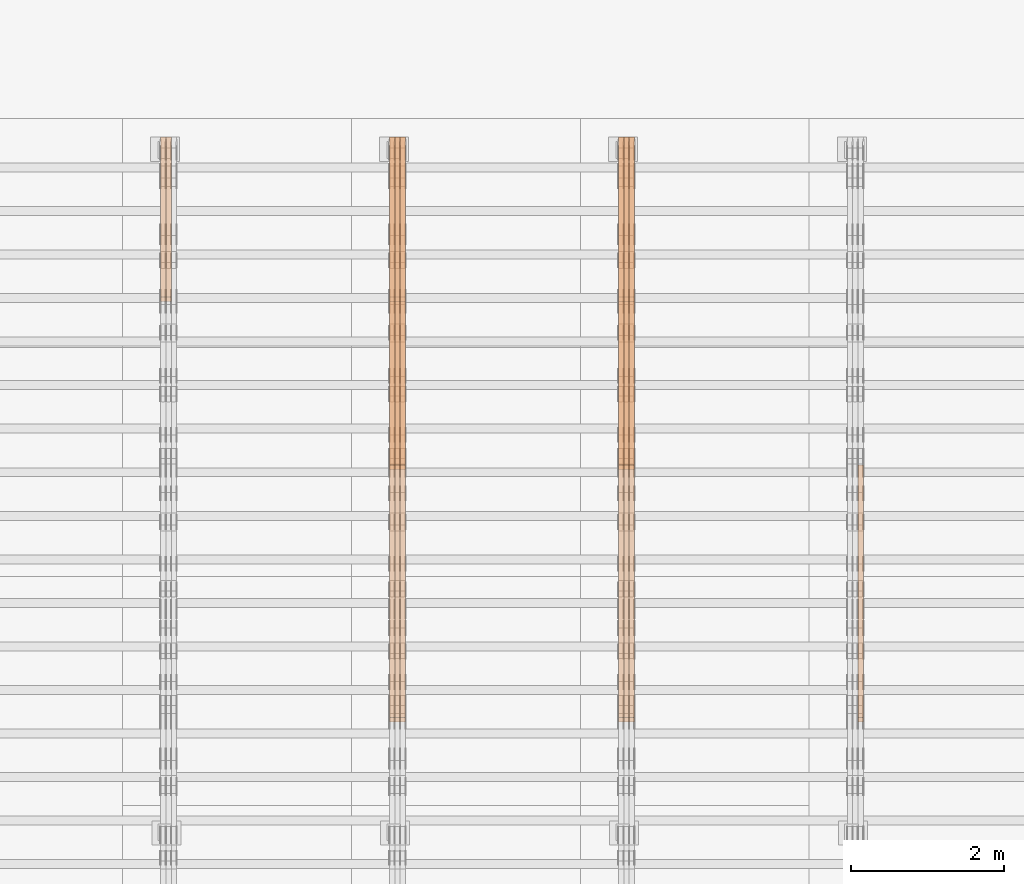
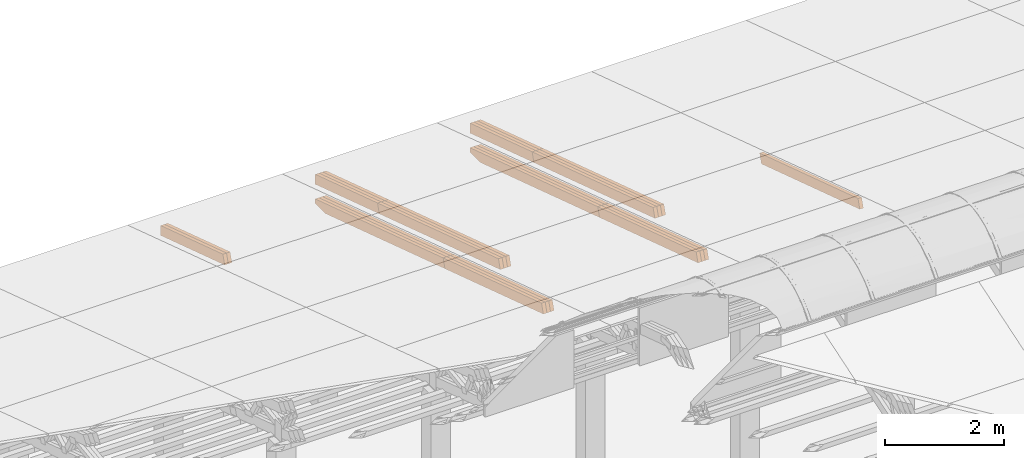
# One storey, part 22 of 385: 27 proxies.
"""IFC2X3 building model written with IfcOpenShell, lengths in millimetres."""

from ifc_helpers import new_model, entity, si_unit, converted_unit, derived_unit, direction, frame, origin, place, context, subcontext, project, spatial, polyline, outline, extrude, source, transform, mapped, material, type_object, type_shapes, element, save


model = new_model("IFC2X3")

# Units and contexts
model_context = context("Model", 3, precision=0.01, world=origin(), true_north=direction((6.12303176911189e-17, 1.0)))
body_context = subcontext(model_context, "Body", "Model", "MODEL_VIEW")
ifc_project = project(units=[si_unit("LENGTHUNIT", "METRE", prefix="MILLI"), si_unit("AREAUNIT", "SQUARE_METRE"), si_unit("VOLUMEUNIT", "CUBIC_METRE"), converted_unit("PLANEANGLEUNIT", "DEGREE", entity("IfcRatioMeasure", 0.0174532925199433), si_unit("PLANEANGLEUNIT", "RADIAN"), dimensions=[0, 0, 0, 0, 0, 0, 0]), si_unit("MASSUNIT", "GRAM", prefix="KILO"), derived_unit("MASSDENSITYUNIT", [(si_unit("MASSUNIT", "GRAM", prefix="KILO"), 1), (si_unit("LENGTHUNIT", "METRE"), -3)]), si_unit("TIMEUNIT", "SECOND"), si_unit("FREQUENCYUNIT", "HERTZ"), si_unit("THERMODYNAMICTEMPERATUREUNIT", "DEGREE_CELSIUS"), derived_unit("THERMALTRANSMITTANCEUNIT", [(si_unit("MASSUNIT", "GRAM", prefix="KILO"), 1), (si_unit("THERMODYNAMICTEMPERATUREUNIT", "KELVIN"), -1), (si_unit("TIMEUNIT", "SECOND"), -3)]), derived_unit("VOLUMETRICFLOWRATEUNIT", [(si_unit("LENGTHUNIT", "METRE"), 3), (si_unit("TIMEUNIT", "SECOND"), -1)]), si_unit("ELECTRICCURRENTUNIT", "AMPERE"), si_unit("ELECTRICVOLTAGEUNIT", "VOLT"), si_unit("POWERUNIT", "WATT"), si_unit("FORCEUNIT", "NEWTON", prefix="KILO"), si_unit("ILLUMINANCEUNIT", "LUX"), si_unit("LUMINOUSFLUXUNIT", "LUMEN"), si_unit("LUMINOUSINTENSITYUNIT", "CANDELA"), derived_unit("USERDEFINED", [(si_unit("MASSUNIT", "GRAM", prefix="KILO"), -1), (si_unit("LENGTHUNIT", "METRE"), -2), (si_unit("TIMEUNIT", "SECOND"), 3), (si_unit("LUMINOUSFLUXUNIT", "LUMEN"), 1)]), derived_unit("LINEARVELOCITYUNIT", [(si_unit("LENGTHUNIT", "METRE"), 1), (si_unit("TIMEUNIT", "SECOND"), -1)]), si_unit("PRESSUREUNIT", "PASCAL"), derived_unit("USERDEFINED", [(si_unit("LENGTHUNIT", "METRE"), -2), (si_unit("MASSUNIT", "GRAM", prefix="KILO"), 1), (si_unit("TIMEUNIT", "SECOND"), -2)])], contexts=[model_context])

# Site, building, storey
site_placement = place(None, origin())
site = spatial("IfcSite", under=ifc_project, at=site_placement, CompositionType="ELEMENT")
building_placement = place(site_placement, origin())
building = spatial("IfcBuilding", under=site, at=building_placement, CompositionType="ELEMENT")
storey_placement = place(building_placement, origin())
storey = spatial("IfcBuildingStorey", under=building, at=storey_placement, Name="Default", CompositionType="ELEMENT", Elevation=0.0)

# Proxies
ifc_material_1 = material(Name="IfcSurfaceStyle #282250")
building_element_proxy_type_1 = type_object("IfcBuildingElementProxyType", Name="T1-B2 282248", PredefinedType="NOTDEFINED", material=ifc_material_1)
shared_shape_1 = source(origin(), body_context, "Body", "SweptSolid", [
    extrude(outline(polyline([(-1738.61933402934, -97.4999466901035), (1738.6190788485, -97.4999466901035), (1738.6191018378, 97.4999466901035), (-1738.61884665697, 97.4999466901035), (-1738.61933402934, -97.4999466901035)])), frame((1738.6191018378, 97.4999528847471, 0.0), z_axis=(0.0, 0.0, 1.0), x_axis=(-1.0, 0.0, 0.0)), (0.0, 0.0, 1.0), 69.9999999999998),
])
type_shapes(building_element_proxy_type_1, [shared_shape_1])
proxy_1_placement = place(building_placement, frame((24385.0, 22140.4521465233, 1306.03026754604), z_axis=(-1.0, 0.0, 0.0), x_axis=(0.0, -0.951056516295124, 0.309016994375039)))
element("IfcBuildingElementProxy", 1, at=proxy_1_placement, inside=storey, type_object=building_element_proxy_type_1, material=ifc_material_1, Name="T1-B2", context=body_context, shape_type="MappedRepresentation", body=[
    mapped(shared_shape_1, transform((0.0, 0.0, 0.0), scale=1.0)),
])
ifc_material_2 = material(Name="IfcSurfaceStyle #249213")
building_element_proxy_type_2 = type_object("IfcBuildingElementProxyType", Name="T1-T2 249211", PredefinedType="NOTDEFINED", material=ifc_material_2)
shared_shape_2 = source(origin(), body_context, "Body", "SweptSolid", [
    extrude(outline(polyline([(-2137.04373183812, -97.5000250291418), (2137.04394104036, -97.5000250291418), (2137.04396402965, 97.5000250291418), (-2137.04417323189, 97.5000250291418), (-2137.04373183812, -97.5000250291418)])), frame((2137.04396402965, 97.5001541485632, 0.0), z_axis=(0.0, 0.0, 1.0), x_axis=(-1.0, 0.0, 0.0)), (0.0, 0.0, 1.0), 69.9999999999997),
])
type_shapes(building_element_proxy_type_2, [shared_shape_2])
proxy_2_placement = place(building_placement, frame((21385.0, 24344.7841397874, 1095.2368156767), z_axis=(-1.0, 0.0, 0.0), x_axis=(0.0, -0.951056516295154, 0.309016994374948)))
element("IfcBuildingElementProxy", 2, at=proxy_2_placement, inside=storey, type_object=building_element_proxy_type_2, material=ifc_material_2, Name="T1-T2", context=body_context, shape_type="MappedRepresentation", body=[
    mapped(shared_shape_2, transform((0.0, 0.0, 0.0), scale=1.0)),
])
ifc_material_3 = material(Name="IfcSurfaceStyle #249156")
building_element_proxy_type_3 = type_object("IfcBuildingElementProxyType", Name="T1-T2 249154", PredefinedType="NOTDEFINED", material=ifc_material_3)
shared_shape_3 = source(origin(), body_context, "Body", "SweptSolid", [
    extrude(outline(polyline([(-2137.04373183812, -97.5000250291418), (2137.04394104036, -97.5000250291418), (2137.04396402965, 97.5000250291418), (-2137.04417323189, 97.5000250291418), (-2137.04373183812, -97.5000250291418)])), frame((2137.04396402965, 97.5001541485632, 0.0), z_axis=(0.0, 0.0, 1.0), x_axis=(-1.0, 0.0, 0.0)), (0.0, 0.0, 1.0), 69.9999999999997),
])
type_shapes(building_element_proxy_type_3, [shared_shape_3])
proxy_3_placement = place(building_placement, frame((21315.0, 24344.7841397874, 1095.2368156767), z_axis=(-1.0, 0.0, 0.0), x_axis=(0.0, -0.951056516295154, 0.309016994374948)))
element("IfcBuildingElementProxy", 3, at=proxy_3_placement, inside=storey, type_object=building_element_proxy_type_3, material=ifc_material_3, Name="T1-T2", context=body_context, shape_type="MappedRepresentation", body=[
    mapped(shared_shape_3, transform((0.0, 0.0, 0.0), scale=1.0)),
])
ifc_material_4 = material(Name="IfcSurfaceStyle #249099")
building_element_proxy_type_4 = type_object("IfcBuildingElementProxyType", Name="T1-T2 249097", PredefinedType="NOTDEFINED", material=ifc_material_4)
shared_shape_4 = source(origin(), body_context, "Body", "SweptSolid", [
    extrude(outline(polyline([(-2137.04373183812, -97.5000250291418), (2137.04394104036, -97.5000250291418), (2137.04396402965, 97.5000250291418), (-2137.04417323189, 97.5000250291418), (-2137.04373183812, -97.5000250291418)])), frame((2137.04396402965, 97.5001541485632, 0.0), z_axis=(0.0, 0.0, 1.0), x_axis=(-1.0, 0.0, 0.0)), (0.0, 0.0, 1.0), 69.9999999999997),
])
type_shapes(building_element_proxy_type_4, [shared_shape_4])
proxy_4_placement = place(building_placement, frame((21245.0, 24344.7841397874, 1095.2368156767), z_axis=(-1.0, 0.0, 0.0), x_axis=(0.0, -0.951056516295154, 0.309016994374948)))
element("IfcBuildingElementProxy", 4, at=proxy_4_placement, inside=storey, type_object=building_element_proxy_type_4, material=ifc_material_4, Name="T1-T2", context=body_context, shape_type="MappedRepresentation", body=[
    mapped(shared_shape_4, transform((0.0, 0.0, 0.0), scale=1.0)),
])
ifc_material_5 = material(Name="IfcSurfaceStyle #249042")
building_element_proxy_type_5 = type_object("IfcBuildingElementProxyType", Name="T1-T3 249040", PredefinedType="NOTDEFINED", material=ifc_material_5)
shared_shape_5 = source(origin(), body_context, "Body", "SweptSolid", [
    extrude(outline(polyline([(-1117.22419189679, -97.5000115568039), (1085.54451125458, -97.5000115568039), (1148.90384954971, 97.5000115568039), (-1117.2241689075, 97.5000115568039), (-1117.22419189679, -97.5000115568039)])), frame((1148.90385201956, 97.5000191595882, 0.0), z_axis=(0.0, 0.0, 1.0), x_axis=(-1.0, 0.0, 0.0)), (0.0, 0.0, 1.0), 69.9999999999999),
])
type_shapes(building_element_proxy_type_5, [shared_shape_5])
proxy_5_placement = place(building_placement, frame((21385.0, 26500.0, 394.964866273674), z_axis=(-1.0, 0.0, 0.0), x_axis=(0.0, -0.951056516295154, 0.309016994374948)))
element("IfcBuildingElementProxy", 5, at=proxy_5_placement, inside=storey, type_object=building_element_proxy_type_5, material=ifc_material_5, Name="T1-T3", context=body_context, shape_type="MappedRepresentation", body=[
    mapped(shared_shape_5, transform((0.0, 0.0, 0.0), scale=1.0)),
])
ifc_material_6 = material(Name="IfcSurfaceStyle #248985")
building_element_proxy_type_6 = type_object("IfcBuildingElementProxyType", Name="T1-T3 248983", PredefinedType="NOTDEFINED", material=ifc_material_6)
shared_shape_6 = source(origin(), body_context, "Body", "SweptSolid", [
    extrude(outline(polyline([(-1117.22419189679, -97.5000115568039), (1085.54451125458, -97.5000115568039), (1148.90384954971, 97.5000115568039), (-1117.2241689075, 97.5000115568039), (-1117.22419189679, -97.5000115568039)])), frame((1148.90385201956, 97.5000191595882, 0.0), z_axis=(0.0, 0.0, 1.0), x_axis=(-1.0, 0.0, 0.0)), (0.0, 0.0, 1.0), 69.9999999999999),
])
type_shapes(building_element_proxy_type_6, [shared_shape_6])
proxy_6_placement = place(building_placement, frame((21315.0, 26500.0, 394.964866273674), z_axis=(-1.0, 0.0, 0.0), x_axis=(0.0, -0.951056516295154, 0.309016994374948)))
element("IfcBuildingElementProxy", 6, at=proxy_6_placement, inside=storey, type_object=building_element_proxy_type_6, material=ifc_material_6, Name="T1-T3", context=body_context, shape_type="MappedRepresentation", body=[
    mapped(shared_shape_6, transform((0.0, 0.0, 0.0), scale=1.0)),
])
ifc_material_7 = material(Name="IfcSurfaceStyle #248928")
building_element_proxy_type_7 = type_object("IfcBuildingElementProxyType", Name="T1-T3 248926", PredefinedType="NOTDEFINED", material=ifc_material_7)
shared_shape_7 = source(origin(), body_context, "Body", "SweptSolid", [
    extrude(outline(polyline([(-1117.22419189679, -97.5000115568039), (1085.54451125458, -97.5000115568039), (1148.90384954971, 97.5000115568039), (-1117.2241689075, 97.5000115568039), (-1117.22419189679, -97.5000115568039)])), frame((1148.90385201956, 97.5000191595882, 0.0), z_axis=(0.0, 0.0, 1.0), x_axis=(-1.0, 0.0, 0.0)), (0.0, 0.0, 1.0), 69.9999999999999),
])
type_shapes(building_element_proxy_type_7, [shared_shape_7])
proxy_7_placement = place(building_placement, frame((21245.0, 26500.0, 394.964866273674), z_axis=(-1.0, 0.0, 0.0), x_axis=(0.0, -0.951056516295154, 0.309016994374948)))
element("IfcBuildingElementProxy", 7, at=proxy_7_placement, inside=storey, type_object=building_element_proxy_type_7, material=ifc_material_7, Name="T1-T3", context=body_context, shape_type="MappedRepresentation", body=[
    mapped(shared_shape_7, transform((0.0, 0.0, 0.0), scale=1.0)),
])
ifc_material_8 = material(Name="IfcSurfaceStyle #247818")
building_element_proxy_type_8 = type_object("IfcBuildingElementProxyType", Name="T1-B2 247816", PredefinedType="NOTDEFINED", material=ifc_material_8)
shared_shape_8 = source(origin(), body_context, "Body", "SweptSolid", [
    extrude(outline(polyline([(-1738.61933402934, -97.4999466901035), (1738.6190788485, -97.4999466901035), (1738.6191018378, 97.4999466901035), (-1738.61884665697, 97.4999466901035), (-1738.61933402934, -97.4999466901035)])), frame((1738.6191018378, 97.4999528847471, 0.0), z_axis=(0.0, 0.0, 1.0), x_axis=(-1.0, 0.0, 0.0)), (0.0, 0.0, 1.0), 69.9999999999998),
])
type_shapes(building_element_proxy_type_8, [shared_shape_8])
proxy_8_placement = place(building_placement, frame((21385.0, 22140.4521465233, 1306.03026754604), z_axis=(-1.0, 0.0, 0.0), x_axis=(0.0, -0.951056516295124, 0.309016994375039)))
element("IfcBuildingElementProxy", 8, at=proxy_8_placement, inside=storey, type_object=building_element_proxy_type_8, material=ifc_material_8, Name="T1-B2", context=body_context, shape_type="MappedRepresentation", body=[
    mapped(shared_shape_8, transform((0.0, 0.0, 0.0), scale=1.0)),
])
ifc_material_9 = material(Name="IfcSurfaceStyle #247761")
building_element_proxy_type_9 = type_object("IfcBuildingElementProxyType", Name="T1-B2 247759", PredefinedType="NOTDEFINED", material=ifc_material_9)
shared_shape_9 = source(origin(), body_context, "Body", "SweptSolid", [
    extrude(outline(polyline([(-1738.61933402934, -97.4999466901035), (1738.6190788485, -97.4999466901035), (1738.6191018378, 97.4999466901035), (-1738.61884665697, 97.4999466901035), (-1738.61933402934, -97.4999466901035)])), frame((1738.6191018378, 97.4999528847471, 0.0), z_axis=(0.0, 0.0, 1.0), x_axis=(-1.0, 0.0, 0.0)), (0.0, 0.0, 1.0), 69.9999999999998),
])
type_shapes(building_element_proxy_type_9, [shared_shape_9])
proxy_9_placement = place(building_placement, frame((21315.0, 22140.4521465233, 1306.03026754604), z_axis=(-1.0, 0.0, 0.0), x_axis=(0.0, -0.951056516295124, 0.309016994375039)))
element("IfcBuildingElementProxy", 9, at=proxy_9_placement, inside=storey, type_object=building_element_proxy_type_9, material=ifc_material_9, Name="T1-B2", context=body_context, shape_type="MappedRepresentation", body=[
    mapped(shared_shape_9, transform((0.0, 0.0, 0.0), scale=1.0)),
])
ifc_material_10 = material(Name="IfcSurfaceStyle #247704")
building_element_proxy_type_10 = type_object("IfcBuildingElementProxyType", Name="T1-B2 247702", PredefinedType="NOTDEFINED", material=ifc_material_10)
shared_shape_10 = source(origin(), body_context, "Body", "SweptSolid", [
    extrude(outline(polyline([(-1738.61933402934, -97.4999466901035), (1738.6190788485, -97.4999466901035), (1738.6191018378, 97.4999466901035), (-1738.61884665697, 97.4999466901035), (-1738.61933402934, -97.4999466901035)])), frame((1738.6191018378, 97.4999528847471, 0.0), z_axis=(0.0, 0.0, 1.0), x_axis=(-1.0, 0.0, 0.0)), (0.0, 0.0, 1.0), 69.9999999999998),
])
type_shapes(building_element_proxy_type_10, [shared_shape_10])
proxy_10_placement = place(building_placement, frame((21245.0, 22140.4521465233, 1306.03026754604), z_axis=(-1.0, 0.0, 0.0), x_axis=(0.0, -0.951056516295124, 0.309016994375039)))
element("IfcBuildingElementProxy", 10, at=proxy_10_placement, inside=storey, type_object=building_element_proxy_type_10, material=ifc_material_10, Name="T1-B2", context=body_context, shape_type="MappedRepresentation", body=[
    mapped(shared_shape_10, transform((0.0, 0.0, 0.0), scale=1.0)),
])
ifc_material_11 = material(Name="IfcSurfaceStyle #247647")
building_element_proxy_type_11 = type_object("IfcBuildingElementProxyType", Name="T1-B1 247645", PredefinedType="NOTDEFINED", material=ifc_material_11)
shared_shape_11 = source(origin(), body_context, "Body", "SweptSolid", [
    extrude(outline(polyline([(-2659.34106034305, -95.9868650736445), (1861.19950396595, -95.9868650736445), (1890.42090463564, -6.05260867570997), (1567.0616890952, 99.0131694114995), (-2659.34103735375, 99.0131694114995), (-2659.34106034305, -95.9868650736445)])), frame((1890.42090463564, 99.013169411504, 0.0), z_axis=(0.0, 0.0, 1.0), x_axis=(-1.0, 0.0, 0.0)), (0.0, 0.0, 1.0), 69.9999999999997),
])
type_shapes(building_element_proxy_type_11, [shared_shape_11])
proxy_11_placement = place(building_placement, frame((21385.0, 26467.5328890438, -99.9234928894624), z_axis=(-1.0, 0.0, 0.0), x_axis=(0.0, -0.951056516295124, 0.309016994375039)))
element("IfcBuildingElementProxy", 11, at=proxy_11_placement, inside=storey, type_object=building_element_proxy_type_11, material=ifc_material_11, Name="T1-B1", context=body_context, shape_type="MappedRepresentation", body=[
    mapped(shared_shape_11, transform((0.0, 0.0, 0.0), scale=1.0)),
])
ifc_material_12 = material(Name="IfcSurfaceStyle #247581")
building_element_proxy_type_12 = type_object("IfcBuildingElementProxyType", Name="T1-B1 247579", PredefinedType="NOTDEFINED", material=ifc_material_12)
shared_shape_12 = source(origin(), body_context, "Body", "SweptSolid", [
    extrude(outline(polyline([(-2659.34106034305, -95.9868650736445), (1861.19950396595, -95.9868650736445), (1890.42090463564, -6.05260867570997), (1567.0616890952, 99.0131694114995), (-2659.34103735375, 99.0131694114995), (-2659.34106034305, -95.9868650736445)])), frame((1890.42090463564, 99.013169411504, 0.0), z_axis=(0.0, 0.0, 1.0), x_axis=(-1.0, 0.0, 0.0)), (0.0, 0.0, 1.0), 69.9999999999997),
])
type_shapes(building_element_proxy_type_12, [shared_shape_12])
proxy_12_placement = place(building_placement, frame((21315.0, 26467.5328890438, -99.9234928894624), z_axis=(-1.0, 0.0, 0.0), x_axis=(0.0, -0.951056516295124, 0.309016994375039)))
element("IfcBuildingElementProxy", 12, at=proxy_12_placement, inside=storey, type_object=building_element_proxy_type_12, material=ifc_material_12, Name="T1-B1", context=body_context, shape_type="MappedRepresentation", body=[
    mapped(shared_shape_12, transform((0.0, 0.0, 0.0), scale=1.0)),
])
ifc_material_13 = material(Name="IfcSurfaceStyle #247515")
building_element_proxy_type_13 = type_object("IfcBuildingElementProxyType", Name="T1-B1 247513", PredefinedType="NOTDEFINED", material=ifc_material_13)
shared_shape_13 = source(origin(), body_context, "Body", "SweptSolid", [
    extrude(outline(polyline([(-2659.34106034305, -95.9868650736445), (1861.19950396595, -95.9868650736445), (1890.42090463564, -6.05260867570997), (1567.0616890952, 99.0131694114995), (-2659.34103735375, 99.0131694114995), (-2659.34106034305, -95.9868650736445)])), frame((1890.42090463564, 99.013169411504, 0.0), z_axis=(0.0, 0.0, 1.0), x_axis=(-1.0, 0.0, 0.0)), (0.0, 0.0, 1.0), 69.9999999999997),
])
type_shapes(building_element_proxy_type_13, [shared_shape_13])
proxy_13_placement = place(building_placement, frame((21245.0, 26467.5328890438, -99.9234928894624), z_axis=(-1.0, 0.0, 0.0), x_axis=(0.0, -0.951056516295124, 0.309016994375039)))
element("IfcBuildingElementProxy", 13, at=proxy_13_placement, inside=storey, type_object=building_element_proxy_type_13, material=ifc_material_13, Name="T1-B1", context=body_context, shape_type="MappedRepresentation", body=[
    mapped(shared_shape_13, transform((0.0, 0.0, 0.0), scale=1.0)),
])
ifc_material_14 = material(Name="IfcSurfaceStyle #214781")
building_element_proxy_type_14 = type_object("IfcBuildingElementProxyType", Name="T1-T2 214779", PredefinedType="NOTDEFINED", material=ifc_material_14)
shared_shape_14 = source(origin(), body_context, "Body", "SweptSolid", [
    extrude(outline(polyline([(-2137.04373183812, -97.5000250291418), (2137.04394104036, -97.5000250291418), (2137.04396402965, 97.5000250291418), (-2137.04417323189, 97.5000250291418), (-2137.04373183812, -97.5000250291418)])), frame((2137.04396402965, 97.5001541485632, 0.0), z_axis=(0.0, 0.0, 1.0), x_axis=(-1.0, 0.0, 0.0)), (0.0, 0.0, 1.0), 69.9999999999997),
])
type_shapes(building_element_proxy_type_14, [shared_shape_14])
proxy_14_placement = place(building_placement, frame((18385.0, 24344.7841397874, 1095.2368156767), z_axis=(-1.0, 0.0, 0.0), x_axis=(0.0, -0.951056516295154, 0.309016994374948)))
element("IfcBuildingElementProxy", 14, at=proxy_14_placement, inside=storey, type_object=building_element_proxy_type_14, material=ifc_material_14, Name="T1-T2", context=body_context, shape_type="MappedRepresentation", body=[
    mapped(shared_shape_14, transform((0.0, 0.0, 0.0), scale=1.0)),
])
ifc_material_15 = material(Name="IfcSurfaceStyle #214724")
building_element_proxy_type_15 = type_object("IfcBuildingElementProxyType", Name="T1-T2 214722", PredefinedType="NOTDEFINED", material=ifc_material_15)
shared_shape_15 = source(origin(), body_context, "Body", "SweptSolid", [
    extrude(outline(polyline([(-2137.04373183812, -97.5000250291418), (2137.04394104036, -97.5000250291418), (2137.04396402965, 97.5000250291418), (-2137.04417323189, 97.5000250291418), (-2137.04373183812, -97.5000250291418)])), frame((2137.04396402965, 97.5001541485632, 0.0), z_axis=(0.0, 0.0, 1.0), x_axis=(-1.0, 0.0, 0.0)), (0.0, 0.0, 1.0), 69.9999999999997),
])
type_shapes(building_element_proxy_type_15, [shared_shape_15])
proxy_15_placement = place(building_placement, frame((18315.0, 24344.7841397874, 1095.2368156767), z_axis=(-1.0, 0.0, 0.0), x_axis=(0.0, -0.951056516295154, 0.309016994374948)))
element("IfcBuildingElementProxy", 15, at=proxy_15_placement, inside=storey, type_object=building_element_proxy_type_15, material=ifc_material_15, Name="T1-T2", context=body_context, shape_type="MappedRepresentation", body=[
    mapped(shared_shape_15, transform((0.0, 0.0, 0.0), scale=1.0)),
])
ifc_material_16 = material(Name="IfcSurfaceStyle #214667")
building_element_proxy_type_16 = type_object("IfcBuildingElementProxyType", Name="T1-T2 214665", PredefinedType="NOTDEFINED", material=ifc_material_16)
shared_shape_16 = source(origin(), body_context, "Body", "SweptSolid", [
    extrude(outline(polyline([(-2137.04373183812, -97.5000250291418), (2137.04394104036, -97.5000250291418), (2137.04396402965, 97.5000250291418), (-2137.04417323189, 97.5000250291418), (-2137.04373183812, -97.5000250291418)])), frame((2137.04396402965, 97.5001541485632, 0.0), z_axis=(0.0, 0.0, 1.0), x_axis=(-1.0, 0.0, 0.0)), (0.0, 0.0, 1.0), 69.9999999999997),
])
type_shapes(building_element_proxy_type_16, [shared_shape_16])
proxy_16_placement = place(building_placement, frame((18245.0, 24344.7841397874, 1095.2368156767), z_axis=(-1.0, 0.0, 0.0), x_axis=(0.0, -0.951056516295154, 0.309016994374948)))
element("IfcBuildingElementProxy", 16, at=proxy_16_placement, inside=storey, type_object=building_element_proxy_type_16, material=ifc_material_16, Name="T1-T2", context=body_context, shape_type="MappedRepresentation", body=[
    mapped(shared_shape_16, transform((0.0, 0.0, 0.0), scale=1.0)),
])
ifc_material_17 = material(Name="IfcSurfaceStyle #214610")
building_element_proxy_type_17 = type_object("IfcBuildingElementProxyType", Name="T1-T3 214608", PredefinedType="NOTDEFINED", material=ifc_material_17)
shared_shape_17 = source(origin(), body_context, "Body", "SweptSolid", [
    extrude(outline(polyline([(-1117.22419189679, -97.5000115568039), (1085.54451125458, -97.5000115568039), (1148.90384954971, 97.5000115568039), (-1117.2241689075, 97.5000115568039), (-1117.22419189679, -97.5000115568039)])), frame((1148.90385201956, 97.5000191595882, 0.0), z_axis=(0.0, 0.0, 1.0), x_axis=(-1.0, 0.0, 0.0)), (0.0, 0.0, 1.0), 69.9999999999999),
])
type_shapes(building_element_proxy_type_17, [shared_shape_17])
proxy_17_placement = place(building_placement, frame((18385.0, 26500.0, 394.964866273674), z_axis=(-1.0, 0.0, 0.0), x_axis=(0.0, -0.951056516295154, 0.309016994374948)))
element("IfcBuildingElementProxy", 17, at=proxy_17_placement, inside=storey, type_object=building_element_proxy_type_17, material=ifc_material_17, Name="T1-T3", context=body_context, shape_type="MappedRepresentation", body=[
    mapped(shared_shape_17, transform((0.0, 0.0, 0.0), scale=1.0)),
])
ifc_material_18 = material(Name="IfcSurfaceStyle #214553")
building_element_proxy_type_18 = type_object("IfcBuildingElementProxyType", Name="T1-T3 214551", PredefinedType="NOTDEFINED", material=ifc_material_18)
shared_shape_18 = source(origin(), body_context, "Body", "SweptSolid", [
    extrude(outline(polyline([(-1117.22419189679, -97.5000115568039), (1085.54451125458, -97.5000115568039), (1148.90384954971, 97.5000115568039), (-1117.2241689075, 97.5000115568039), (-1117.22419189679, -97.5000115568039)])), frame((1148.90385201956, 97.5000191595882, 0.0), z_axis=(0.0, 0.0, 1.0), x_axis=(-1.0, 0.0, 0.0)), (0.0, 0.0, 1.0), 69.9999999999999),
])
type_shapes(building_element_proxy_type_18, [shared_shape_18])
proxy_18_placement = place(building_placement, frame((18315.0, 26500.0, 394.964866273674), z_axis=(-1.0, 0.0, 0.0), x_axis=(0.0, -0.951056516295154, 0.309016994374948)))
element("IfcBuildingElementProxy", 18, at=proxy_18_placement, inside=storey, type_object=building_element_proxy_type_18, material=ifc_material_18, Name="T1-T3", context=body_context, shape_type="MappedRepresentation", body=[
    mapped(shared_shape_18, transform((0.0, 0.0, 0.0), scale=1.0)),
])
ifc_material_19 = material(Name="IfcSurfaceStyle #214496")
building_element_proxy_type_19 = type_object("IfcBuildingElementProxyType", Name="T1-T3 214494", PredefinedType="NOTDEFINED", material=ifc_material_19)
shared_shape_19 = source(origin(), body_context, "Body", "SweptSolid", [
    extrude(outline(polyline([(-1117.22419189679, -97.5000115568039), (1085.54451125458, -97.5000115568039), (1148.90384954971, 97.5000115568039), (-1117.2241689075, 97.5000115568039), (-1117.22419189679, -97.5000115568039)])), frame((1148.90385201956, 97.5000191595882, 0.0), z_axis=(0.0, 0.0, 1.0), x_axis=(-1.0, 0.0, 0.0)), (0.0, 0.0, 1.0), 69.9999999999999),
])
type_shapes(building_element_proxy_type_19, [shared_shape_19])
proxy_19_placement = place(building_placement, frame((18245.0, 26500.0, 394.964866273674), z_axis=(-1.0, 0.0, 0.0), x_axis=(0.0, -0.951056516295154, 0.309016994374948)))
element("IfcBuildingElementProxy", 19, at=proxy_19_placement, inside=storey, type_object=building_element_proxy_type_19, material=ifc_material_19, Name="T1-T3", context=body_context, shape_type="MappedRepresentation", body=[
    mapped(shared_shape_19, transform((0.0, 0.0, 0.0), scale=1.0)),
])
ifc_material_20 = material(Name="IfcSurfaceStyle #213386")
building_element_proxy_type_20 = type_object("IfcBuildingElementProxyType", Name="T1-B2 213384", PredefinedType="NOTDEFINED", material=ifc_material_20)
shared_shape_20 = source(origin(), body_context, "Body", "SweptSolid", [
    extrude(outline(polyline([(-1738.61933402934, -97.4999466901035), (1738.6190788485, -97.4999466901035), (1738.6191018378, 97.4999466901035), (-1738.61884665697, 97.4999466901035), (-1738.61933402934, -97.4999466901035)])), frame((1738.6191018378, 97.4999528847471, 0.0), z_axis=(0.0, 0.0, 1.0), x_axis=(-1.0, 0.0, 0.0)), (0.0, 0.0, 1.0), 69.9999999999998),
])
type_shapes(building_element_proxy_type_20, [shared_shape_20])
proxy_20_placement = place(building_placement, frame((18385.0, 22140.4521465233, 1306.03026754604), z_axis=(-1.0, 0.0, 0.0), x_axis=(0.0, -0.951056516295124, 0.309016994375039)))
element("IfcBuildingElementProxy", 20, at=proxy_20_placement, inside=storey, type_object=building_element_proxy_type_20, material=ifc_material_20, Name="T1-B2", context=body_context, shape_type="MappedRepresentation", body=[
    mapped(shared_shape_20, transform((0.0, 0.0, 0.0), scale=1.0)),
])
ifc_material_21 = material(Name="IfcSurfaceStyle #213329")
building_element_proxy_type_21 = type_object("IfcBuildingElementProxyType", Name="T1-B2 213327", PredefinedType="NOTDEFINED", material=ifc_material_21)
shared_shape_21 = source(origin(), body_context, "Body", "SweptSolid", [
    extrude(outline(polyline([(-1738.61933402934, -97.4999466901035), (1738.6190788485, -97.4999466901035), (1738.6191018378, 97.4999466901035), (-1738.61884665697, 97.4999466901035), (-1738.61933402934, -97.4999466901035)])), frame((1738.6191018378, 97.4999528847471, 0.0), z_axis=(0.0, 0.0, 1.0), x_axis=(-1.0, 0.0, 0.0)), (0.0, 0.0, 1.0), 69.9999999999998),
])
type_shapes(building_element_proxy_type_21, [shared_shape_21])
proxy_21_placement = place(building_placement, frame((18315.0, 22140.4521465233, 1306.03026754604), z_axis=(-1.0, 0.0, 0.0), x_axis=(0.0, -0.951056516295124, 0.309016994375039)))
element("IfcBuildingElementProxy", 21, at=proxy_21_placement, inside=storey, type_object=building_element_proxy_type_21, material=ifc_material_21, Name="T1-B2", context=body_context, shape_type="MappedRepresentation", body=[
    mapped(shared_shape_21, transform((0.0, 0.0, 0.0), scale=1.0)),
])
ifc_material_22 = material(Name="IfcSurfaceStyle #213272")
building_element_proxy_type_22 = type_object("IfcBuildingElementProxyType", Name="T1-B2 213270", PredefinedType="NOTDEFINED", material=ifc_material_22)
shared_shape_22 = source(origin(), body_context, "Body", "SweptSolid", [
    extrude(outline(polyline([(-1738.61933402934, -97.4999466901035), (1738.6190788485, -97.4999466901035), (1738.6191018378, 97.4999466901035), (-1738.61884665697, 97.4999466901035), (-1738.61933402934, -97.4999466901035)])), frame((1738.6191018378, 97.4999528847471, 0.0), z_axis=(0.0, 0.0, 1.0), x_axis=(-1.0, 0.0, 0.0)), (0.0, 0.0, 1.0), 69.9999999999998),
])
type_shapes(building_element_proxy_type_22, [shared_shape_22])
proxy_22_placement = place(building_placement, frame((18245.0, 22140.4521465233, 1306.03026754604), z_axis=(-1.0, 0.0, 0.0), x_axis=(0.0, -0.951056516295124, 0.309016994375039)))
element("IfcBuildingElementProxy", 22, at=proxy_22_placement, inside=storey, type_object=building_element_proxy_type_22, material=ifc_material_22, Name="T1-B2", context=body_context, shape_type="MappedRepresentation", body=[
    mapped(shared_shape_22, transform((0.0, 0.0, 0.0), scale=1.0)),
])
ifc_material_23 = material(Name="IfcSurfaceStyle #213215")
building_element_proxy_type_23 = type_object("IfcBuildingElementProxyType", Name="T1-B1 213213", PredefinedType="NOTDEFINED", material=ifc_material_23)
shared_shape_23 = source(origin(), body_context, "Body", "SweptSolid", [
    extrude(outline(polyline([(-2659.34106034305, -95.9868650736445), (1861.19950396595, -95.9868650736445), (1890.42090463564, -6.05260867570997), (1567.0616890952, 99.0131694114995), (-2659.34103735375, 99.0131694114995), (-2659.34106034305, -95.9868650736445)])), frame((1890.42090463564, 99.013169411504, 0.0), z_axis=(0.0, 0.0, 1.0), x_axis=(-1.0, 0.0, 0.0)), (0.0, 0.0, 1.0), 69.9999999999997),
])
type_shapes(building_element_proxy_type_23, [shared_shape_23])
proxy_23_placement = place(building_placement, frame((18385.0, 26467.5328890438, -99.9234928894624), z_axis=(-1.0, 0.0, 0.0), x_axis=(0.0, -0.951056516295124, 0.309016994375039)))
element("IfcBuildingElementProxy", 23, at=proxy_23_placement, inside=storey, type_object=building_element_proxy_type_23, material=ifc_material_23, Name="T1-B1", context=body_context, shape_type="MappedRepresentation", body=[
    mapped(shared_shape_23, transform((0.0, 0.0, 0.0), scale=1.0)),
])
ifc_material_24 = material(Name="IfcSurfaceStyle #213149")
building_element_proxy_type_24 = type_object("IfcBuildingElementProxyType", Name="T1-B1 213147", PredefinedType="NOTDEFINED", material=ifc_material_24)
shared_shape_24 = source(origin(), body_context, "Body", "SweptSolid", [
    extrude(outline(polyline([(-2659.34106034305, -95.9868650736445), (1861.19950396595, -95.9868650736445), (1890.42090463564, -6.05260867570997), (1567.0616890952, 99.0131694114995), (-2659.34103735375, 99.0131694114995), (-2659.34106034305, -95.9868650736445)])), frame((1890.42090463564, 99.013169411504, 0.0), z_axis=(0.0, 0.0, 1.0), x_axis=(-1.0, 0.0, 0.0)), (0.0, 0.0, 1.0), 69.9999999999997),
])
type_shapes(building_element_proxy_type_24, [shared_shape_24])
proxy_24_placement = place(building_placement, frame((18315.0, 26467.5328890438, -99.9234928894624), z_axis=(-1.0, 0.0, 0.0), x_axis=(0.0, -0.951056516295124, 0.309016994375039)))
element("IfcBuildingElementProxy", 24, at=proxy_24_placement, inside=storey, type_object=building_element_proxy_type_24, material=ifc_material_24, Name="T1-B1", context=body_context, shape_type="MappedRepresentation", body=[
    mapped(shared_shape_24, transform((0.0, 0.0, 0.0), scale=1.0)),
])
ifc_material_25 = material(Name="IfcSurfaceStyle #213083")
building_element_proxy_type_25 = type_object("IfcBuildingElementProxyType", Name="T1-B1 213081", PredefinedType="NOTDEFINED", material=ifc_material_25)
shared_shape_25 = source(origin(), body_context, "Body", "SweptSolid", [
    extrude(outline(polyline([(-2659.34106034305, -95.9868650736445), (1861.19950396595, -95.9868650736445), (1890.42090463564, -6.05260867570997), (1567.0616890952, 99.0131694114995), (-2659.34103735375, 99.0131694114995), (-2659.34106034305, -95.9868650736445)])), frame((1890.42090463564, 99.013169411504, 0.0), z_axis=(0.0, 0.0, 1.0), x_axis=(-1.0, 0.0, 0.0)), (0.0, 0.0, 1.0), 69.9999999999997),
])
type_shapes(building_element_proxy_type_25, [shared_shape_25])
proxy_25_placement = place(building_placement, frame((18245.0, 26467.5328890438, -99.9234928894624), z_axis=(-1.0, 0.0, 0.0), x_axis=(0.0, -0.951056516295124, 0.309016994375039)))
element("IfcBuildingElementProxy", 25, at=proxy_25_placement, inside=storey, type_object=building_element_proxy_type_25, material=ifc_material_25, Name="T1-B1", context=body_context, shape_type="MappedRepresentation", body=[
    mapped(shared_shape_25, transform((0.0, 0.0, 0.0), scale=1.0)),
])
ifc_material_26 = material(Name="IfcSurfaceStyle #180121")
building_element_proxy_type_26 = type_object("IfcBuildingElementProxyType", Name="T1-T3 180119", PredefinedType="NOTDEFINED", material=ifc_material_26)
shared_shape_26 = source(origin(), body_context, "Body", "SweptSolid", [
    extrude(outline(polyline([(-1117.22419189679, -97.5000115568039), (1085.54451125458, -97.5000115568039), (1148.90384954971, 97.5000115568039), (-1117.2241689075, 97.5000115568039), (-1117.22419189679, -97.5000115568039)])), frame((1148.90385201956, 97.5000191595882, 0.0), z_axis=(0.0, 0.0, 1.0), x_axis=(-1.0, 0.0, 0.0)), (0.0, 0.0, 1.0), 69.9999999999999),
])
type_shapes(building_element_proxy_type_26, [shared_shape_26])
proxy_26_placement = place(building_placement, frame((15315.0, 26500.0, 394.964866273674), z_axis=(-1.0, 0.0, 0.0), x_axis=(0.0, -0.951056516295154, 0.309016994374948)))
element("IfcBuildingElementProxy", 26, at=proxy_26_placement, inside=storey, type_object=building_element_proxy_type_26, material=ifc_material_26, Name="T1-T3", context=body_context, shape_type="MappedRepresentation", body=[
    mapped(shared_shape_26, transform((0.0, 0.0, 0.0), scale=1.0)),
])
ifc_material_27 = material(Name="IfcSurfaceStyle #180064")
building_element_proxy_type_27 = type_object("IfcBuildingElementProxyType", Name="T1-T3 180062", PredefinedType="NOTDEFINED", material=ifc_material_27)
shared_shape_27 = source(origin(), body_context, "Body", "SweptSolid", [
    extrude(outline(polyline([(-1117.22419189679, -97.5000115568039), (1085.54451125458, -97.5000115568039), (1148.90384954971, 97.5000115568039), (-1117.2241689075, 97.5000115568039), (-1117.22419189679, -97.5000115568039)])), frame((1148.90385201956, 97.5000191595882, 0.0), z_axis=(0.0, 0.0, 1.0), x_axis=(-1.0, 0.0, 0.0)), (0.0, 0.0, 1.0), 69.9999999999999),
])
type_shapes(building_element_proxy_type_27, [shared_shape_27])
proxy_27_placement = place(building_placement, frame((15245.0, 26500.0, 394.964866273674), z_axis=(-1.0, 0.0, 0.0), x_axis=(0.0, -0.951056516295154, 0.309016994374948)))
element("IfcBuildingElementProxy", 27, at=proxy_27_placement, inside=storey, type_object=building_element_proxy_type_27, material=ifc_material_27, Name="T1-T3", context=body_context, shape_type="MappedRepresentation", body=[
    mapped(shared_shape_27, transform((0.0, 0.0, 0.0), scale=1.0)),
])

save(model, "model.ifc")
